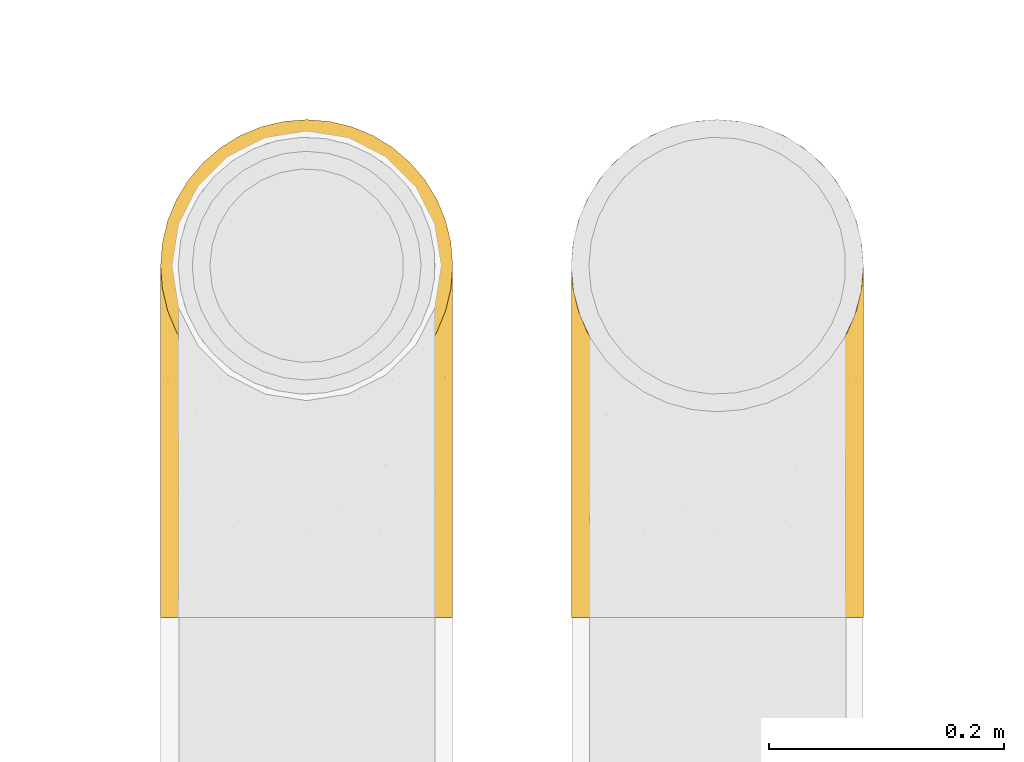
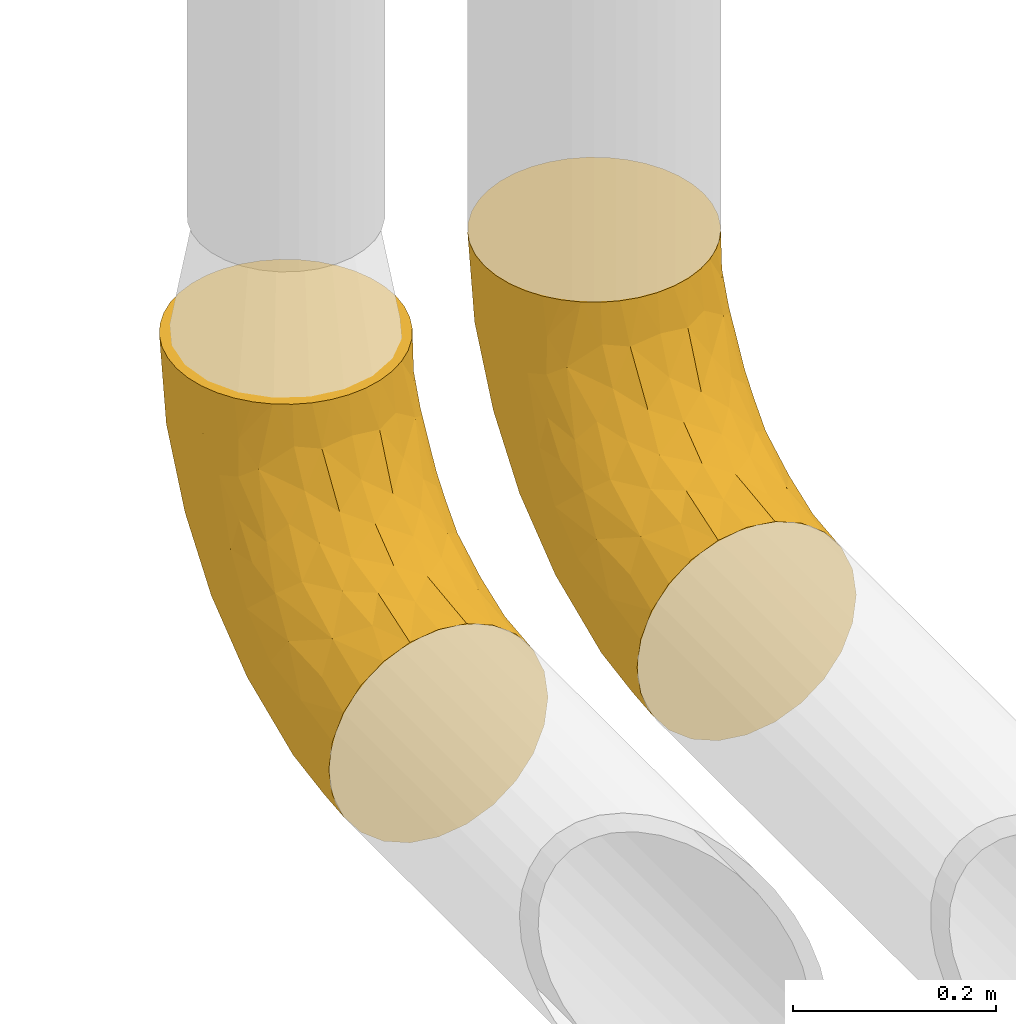
# One storey, part 41 of 93: 2 coverings.
"""IFC2X3 building model written with IfcOpenShell, lengths in millimetres."""

from ifc_helpers import new_model, entity, si_unit, converted_unit, derived_unit, direction, frame, origin, place, context, subcontext, project, spatial, faceted_brep, element, save


model = new_model("IFC2X3")

# Units and contexts
model_context = context("Model", 3, precision=0.01, world=origin(), true_north=direction((6.12303176911189e-17, 1.0)))
body_context = subcontext(model_context, "Body", "Model", "MODEL_VIEW")
ifc_project = project(units=[si_unit("LENGTHUNIT", "METRE", prefix="MILLI"), si_unit("AREAUNIT", "SQUARE_METRE"), si_unit("VOLUMEUNIT", "CUBIC_METRE"), converted_unit("PLANEANGLEUNIT", "DEGREE", entity("IfcRatioMeasure", 0.0174532925199433), si_unit("PLANEANGLEUNIT", "RADIAN"), dimensions=[0, 0, 0, 0, 0, 0, 0]), si_unit("MASSUNIT", "GRAM", prefix="KILO"), derived_unit("MASSDENSITYUNIT", [(si_unit("MASSUNIT", "GRAM", prefix="KILO"), 1), (si_unit("LENGTHUNIT", "METRE"), -3)]), derived_unit("MOMENTOFINERTIAUNIT", [(si_unit("LENGTHUNIT", "METRE"), 4)]), si_unit("TIMEUNIT", "SECOND"), si_unit("FREQUENCYUNIT", "HERTZ"), si_unit("THERMODYNAMICTEMPERATUREUNIT", "DEGREE_CELSIUS"), derived_unit("THERMALTRANSMITTANCEUNIT", [(si_unit("MASSUNIT", "GRAM", prefix="KILO"), 1), (si_unit("THERMODYNAMICTEMPERATUREUNIT", "KELVIN"), -1), (si_unit("TIMEUNIT", "SECOND"), -3)]), derived_unit("VOLUMETRICFLOWRATEUNIT", [(si_unit("LENGTHUNIT", "METRE"), 3), (si_unit("TIMEUNIT", "SECOND"), -1)]), derived_unit("MASSFLOWRATEUNIT", [(si_unit("MASSUNIT", "GRAM", prefix="KILO"), 1), (si_unit("TIMEUNIT", "SECOND"), -1)]), derived_unit("ROTATIONALFREQUENCYUNIT", [(si_unit("TIMEUNIT", "SECOND"), -1)]), si_unit("ELECTRICCURRENTUNIT", "AMPERE"), si_unit("ELECTRICVOLTAGEUNIT", "VOLT"), si_unit("POWERUNIT", "WATT"), si_unit("FORCEUNIT", "NEWTON", prefix="KILO"), si_unit("ILLUMINANCEUNIT", "LUX"), si_unit("LUMINOUSFLUXUNIT", "LUMEN"), si_unit("LUMINOUSINTENSITYUNIT", "CANDELA"), derived_unit("USERDEFINED", [(si_unit("MASSUNIT", "GRAM", prefix="KILO"), -1), (si_unit("LENGTHUNIT", "METRE"), -2), (si_unit("TIMEUNIT", "SECOND"), 3), (si_unit("LUMINOUSFLUXUNIT", "LUMEN"), 1)]), derived_unit("LINEARVELOCITYUNIT", [(si_unit("LENGTHUNIT", "METRE"), 1), (si_unit("TIMEUNIT", "SECOND"), -1)]), si_unit("PRESSUREUNIT", "PASCAL"), derived_unit("USERDEFINED", [(si_unit("LENGTHUNIT", "METRE"), -2), (si_unit("MASSUNIT", "GRAM", prefix="KILO"), 1), (si_unit("TIMEUNIT", "SECOND"), -2)]), derived_unit("LINEARFORCEUNIT", [(si_unit("MASSUNIT", "GRAM", prefix="KILO"), 1), (si_unit("LENGTHUNIT", "METRE"), 1), (si_unit("TIMEUNIT", "SECOND"), -2), (si_unit("LENGTHUNIT", "METRE"), -1)]), derived_unit("PLANARFORCEUNIT", [(si_unit("MASSUNIT", "GRAM", prefix="KILO"), 1), (si_unit("LENGTHUNIT", "METRE"), 1), (si_unit("TIMEUNIT", "SECOND"), -2), (si_unit("LENGTHUNIT", "METRE"), -2)])], contexts=[model_context])

# Site, building, storey
site_placement = place(None, origin())
site = spatial("IfcSite", under=ifc_project, at=site_placement, CompositionType="ELEMENT")
building_placement = place(site_placement, origin())
building = spatial("IfcBuilding", under=site, at=building_placement, CompositionType="ELEMENT")
storey_placement = place(building_placement, frame((0.0, 0.0, -4200.0)))
storey = spatial("IfcBuildingStorey", under=building, at=storey_placement, CompositionType="ELEMENT", Elevation=-4200.0)

# Coverings
covering_1_placement = place(storey_placement, frame((31303.9, 10648.4, 2673.9)))
element("IfcCovering", 1, at=covering_1_placement, inside=storey, Name=":ADSK_", ObjectType=":ADSK_", PredefinedType="INSULATION", context=body_context, shape_type="Brep", body=[
    faceted_brep([(249.06, 282.13, 426.1), (250.6, 301.6, 426.1), (249.06, 321.07, 426.1), (244.5, 340.07, 426.1), (237.02, 358.12, 426.1), (226.82, 374.78, 426.1), (214.13, 389.63, 426.1), (199.27, 402.32, 426.1), (182.61, 412.53, 426.1), (164.56, 420.0, 426.1), (145.56, 424.56, 426.1), (126.1, 426.1, 426.1), (106.62, 424.56, 426.1), (87.62, 420.0, 426.1), (69.57, 412.52, 426.1), (52.91, 402.32, 426.1), (38.06, 389.63, 426.1), (25.37, 374.77, 426.1), (15.16, 358.11, 426.1), (7.69, 340.06, 426.1), (3.13, 321.06, 426.1), (1.6, 301.6, 426.1), (3.13, 282.12, 426.1), (7.69, 263.12, 426.1), (15.17, 245.07, 426.1), (25.37, 228.41, 426.1), (38.06, 213.56, 426.1), (52.92, 200.87, 426.1), (69.58, 190.66, 426.1), (87.63, 183.19, 426.1), (106.63, 178.63, 426.1), (126.1, 177.1, 426.1), (145.57, 178.63, 426.1), (164.57, 183.19, 426.1), (182.62, 190.67, 426.1), (199.28, 200.87, 426.1), (214.13, 213.56, 426.1), (226.82, 228.42, 426.1), (237.03, 245.08, 426.1), (244.5, 263.13, 426.1), (38.06, 1.6, 214.13), (18.28, 1.6, 188.35), (5.84, 1.6, 158.32), (1.6, 1.6, 126.1), (5.84, 1.6, 93.87), (18.28, 1.6, 63.85), (38.06, 1.6, 38.06), (63.85, 1.6, 18.28), (93.87, 1.6, 5.84), (126.1, 1.6, 1.6), (158.32, 1.6, 5.84), (188.35, 1.6, 18.28), (214.13, 1.6, 38.06), (233.92, 1.6, 63.85), (246.35, 1.6, 93.87), (250.6, 1.6, 126.1), (246.35, 1.6, 158.32), (233.92, 1.6, 188.35), (214.13, 1.6, 214.13), (188.35, 1.6, 233.92), (158.32, 1.6, 246.35), (126.1, 1.6, 250.6), (93.87, 1.6, 246.35), (63.85, 1.6, 233.92), (126.1, 68.0, 6.82), (159.79, 159.76, 37.17), (171.65, 77.64, 17.24), (148.37, 97.22, 14.57), (170.98, 405.8, 327.19), (151.53, 392.04, 266.32), (148.43, 414.51, 336.7), (126.1, 132.77, 22.37), (126.1, 194.31, 47.86), (126.1, 405.32, 294.92), (126.1, 379.83, 233.38), (163.78, 320.36, 154.69), (158.07, 248.34, 85.81), (126.1, 301.76, 125.93), (216.14, 366.71, 300.91), (230.6, 325.62, 252.35), (215.18, 335.07, 229.77), (237.51, 94.41, 82.86), (220.0, 134.75, 68.32), (240.62, 179.18, 125.85), (126.1, 251.11, 82.67), (186.25, 211.76, 75.22), (126.1, 345.02, 176.58), (238.35, 342.12, 329.96), (222.84, 59.52, 52.19), (247.51, 211.65, 174.79), (242.96, 297.5, 252.75), (248.72, 276.6, 259.55), (247.51, 110.66, 117.26), (198.61, 95.34, 36.0), (238.33, 253.95, 178.0), (250.6, 116.4, 148.93), (250.6, 168.27, 176.65), (185.0, 369.41, 245.67), (250.6, 213.73, 213.96), (196.36, 306.0, 162.34), (204.33, 391.55, 352.45), (126.1, 420.87, 359.69), (250.6, 295.83, 367.57), (248.1, 308.28, 319.13), (250.6, 251.04, 259.42), (250.6, 278.76, 311.29), (250.6, 60.12, 131.86), (210.72, 234.78, 111.84), (228.5, 221.69, 127.68), (202.78, 163.96, 62.63), (223.0, 288.95, 180.25), (161.59, 111.98, 283.07), (126.1, 89.35, 274.11), (154.22, 71.87, 261.78), (245.5, 64.74, 168.98), (229.55, 215.82, 340.36), (225.61, 222.14, 380.61), (214.98, 201.51, 353.11), (208.87, 126.52, 261.04), (222.51, 172.37, 285.47), (202.61, 163.8, 306.07), (240.31, 234.78, 334.75), (182.2, 167.67, 336.17), (158.82, 173.96, 374.65), (156.41, 143.34, 316.38), (247.49, 121.95, 181.78), (244.95, 258.85, 371.73), (229.45, 143.25, 244.15), (246.68, 169.65, 216.03), (229.97, 51.0, 200.06), (126.1, 47.02, 256.58), (175.48, 45.74, 245.7), (182.39, 93.2, 260.83), (126.1, 171.12, 380.67), (126.1, 153.58, 338.35), (183.62, 136.31, 292.7), (126.1, 125.69, 302.0), (244.1, 205.48, 264.25), (248.44, 249.33, 302.28), (209.02, 66.24, 229.31), (235.25, 204.54, 297.75), (235.58, 177.77, 262.06), (183.86, 185.41, 379.14), (235.31, 107.5, 210.47), (5.51, 169.66, 216.03), (22.75, 143.22, 244.14), (16.61, 177.76, 262.04), (90.61, 111.98, 283.07), (69.8, 93.2, 260.83), (97.97, 71.87, 261.78), (26.59, 222.13, 380.61), (1.6, 116.4, 148.93), (4.7, 121.95, 181.78), (1.6, 168.27, 176.65), (95.79, 143.34, 316.38), (22.64, 215.81, 340.36), (11.89, 234.77, 334.74), (68.58, 136.3, 292.7), (93.38, 173.96, 374.65), (6.69, 64.74, 168.98), (1.6, 60.12, 131.86), (1.6, 213.73, 213.96), (8.09, 205.49, 264.24), (16.94, 204.53, 297.74), (43.34, 126.53, 261.06), (22.22, 51.0, 200.06), (43.17, 66.24, 229.31), (70.0, 167.66, 336.17), (1.6, 278.76, 311.29), (7.24, 258.84, 371.72), (1.6, 295.83, 367.57), (76.71, 45.74, 245.7), (68.34, 185.4, 379.14), (16.88, 107.5, 210.47), (37.22, 201.5, 353.11), (29.69, 172.36, 285.46), (49.59, 163.8, 306.07), (3.75, 249.33, 302.29), (1.6, 251.04, 259.42), (4.68, 110.66, 117.26), (29.2, 288.95, 180.25), (21.6, 325.63, 252.36), (37.02, 335.08, 229.77), (4.68, 211.65, 174.79), (67.18, 369.41, 245.69), (81.2, 405.8, 327.2), (100.65, 392.04, 266.32), (13.83, 342.12, 329.97), (14.68, 94.41, 82.86), (29.35, 59.51, 52.19), (53.58, 95.34, 36.0), (9.24, 297.5, 252.75), (3.47, 276.6, 259.54), (11.57, 179.18, 125.85), (92.4, 159.76, 37.17), (80.54, 77.64, 17.24), (47.86, 391.55, 352.45), (32.19, 134.74, 68.32), (88.4, 320.36, 154.69), (55.83, 306.02, 162.36), (103.83, 97.22, 14.57), (94.12, 248.34, 85.81), (65.94, 211.76, 75.22), (41.48, 234.79, 111.84), (103.76, 414.51, 336.71), (4.09, 308.29, 319.13), (13.86, 253.95, 178.0), (23.69, 221.69, 127.67), (36.04, 366.7, 300.91), (49.41, 163.97, 62.64)], [[[0, 1, 2, 3, 4, 5, 6, 7, 8, 9, 10, 11, 12, 13, 14, 15, 16, 17, 18, 19, 20, 21, 22, 23, 24, 25, 26, 27, 28, 29, 30, 31, 32, 33, 34, 35, 36, 37, 38, 39]], [[40, 41, 42, 43, 44, 45, 46, 47, 48, 49, 50, 51, 52, 53, 54, 55, 56, 57, 58, 59, 60, 61, 62, 63]], [[49, 64, 50]], [[65, 66, 67]], [[68, 69, 70]], [[65, 71, 72]], [[71, 65, 67]], [[73, 69, 74]], [[75, 76, 77]], [[78, 79, 80]], [[65, 72, 76]], [[51, 50, 66]], [[81, 82, 83]], [[84, 76, 72]], [[76, 85, 65]], [[74, 69, 86]], [[5, 87, 78]], [[52, 88, 53]], [[89, 90, 91]], [[55, 54, 92]], [[82, 88, 93]], [[94, 89, 83]], [[87, 90, 79]], [[95, 89, 96]], [[5, 4, 87]], [[83, 89, 92]], [[90, 89, 94]], [[78, 80, 97]], [[65, 85, 93]], [[95, 92, 89]], [[96, 89, 98]], [[99, 75, 97]], [[3, 87, 4]], [[90, 94, 79]], [[8, 68, 9]], [[75, 77, 86]], [[100, 7, 6]], [[83, 92, 81]], [[70, 10, 9]], [[101, 70, 73]], [[54, 81, 92]], [[68, 70, 9]], [[97, 100, 78]], [[7, 100, 8]], [[8, 100, 68]], [[101, 11, 10]], [[2, 102, 103]], [[100, 6, 5]], [[104, 91, 105]], [[102, 105, 103]], [[92, 95, 106]], [[1, 102, 2]], [[81, 54, 53]], [[107, 108, 82]], [[68, 97, 69]], [[2, 103, 3]], [[98, 89, 91]], [[90, 103, 91]], [[90, 87, 103]], [[107, 85, 99]], [[103, 87, 3]], [[100, 97, 68]], [[100, 5, 78]], [[93, 52, 51]], [[75, 69, 97]], [[75, 86, 69]], [[88, 81, 53]], [[55, 92, 106]], [[93, 51, 66]], [[109, 82, 93]], [[108, 94, 83]], [[79, 94, 110]], [[107, 99, 110]], [[85, 75, 99]], [[77, 76, 84]], [[75, 85, 76]], [[110, 94, 108]], [[109, 107, 82]], [[82, 108, 83]], [[110, 108, 107]], [[67, 50, 64]], [[93, 66, 65]], [[80, 79, 110]], [[78, 87, 79]], [[110, 99, 80]], [[97, 80, 99]], [[73, 70, 69]], [[10, 70, 101]], [[50, 67, 66]], [[71, 67, 64]], [[105, 91, 103]], [[91, 104, 98]], [[93, 88, 52]], [[81, 88, 82]], [[93, 85, 109]], [[107, 109, 85]], [[111, 112, 113]], [[56, 55, 106]], [[106, 114, 56]], [[115, 116, 117]], [[118, 119, 120]], [[116, 115, 121]], [[95, 114, 106]], [[122, 123, 124]], [[95, 125, 114]], [[102, 39, 126]], [[119, 118, 127]], [[96, 98, 128]], [[114, 57, 56]], [[57, 129, 58]], [[36, 35, 116]], [[61, 60, 130]], [[113, 131, 132]], [[32, 133, 123]], [[134, 123, 133]], [[113, 112, 130]], [[126, 116, 121]], [[131, 113, 60]], [[124, 111, 135]], [[122, 124, 135]], [[111, 136, 112]], [[128, 98, 137]], [[137, 104, 138]], [[132, 135, 111]], [[126, 105, 102]], [[60, 113, 130]], [[127, 118, 139]], [[126, 39, 38]], [[140, 121, 115]], [[1, 0, 102]], [[126, 121, 138]], [[38, 37, 116]], [[129, 139, 58]], [[0, 39, 102]], [[127, 141, 119]], [[116, 126, 38]], [[142, 34, 33]], [[142, 123, 122]], [[137, 98, 104]], [[31, 133, 32]], [[139, 132, 131]], [[123, 134, 124]], [[35, 34, 142]], [[35, 117, 116]], [[124, 134, 136]], [[117, 122, 120]], [[33, 32, 123]], [[33, 123, 142]], [[37, 36, 116]], [[58, 139, 59]], [[129, 114, 143]], [[105, 138, 104]], [[125, 128, 143]], [[125, 95, 96]], [[118, 135, 132]], [[120, 122, 135]], [[132, 139, 118]], [[127, 139, 143]], [[114, 129, 57]], [[139, 129, 143]], [[60, 59, 131]], [[139, 131, 59]], [[128, 125, 96]], [[143, 114, 125]], [[118, 120, 135]], [[117, 120, 119]], [[143, 128, 127]], [[141, 128, 137]], [[136, 111, 124]], [[132, 111, 113]], [[122, 117, 142]], [[35, 142, 117]], [[117, 119, 115]], [[119, 141, 140]], [[126, 138, 105]], [[137, 138, 121]], [[128, 141, 127]], [[140, 141, 137]], [[121, 140, 137]], [[119, 140, 115]], [[144, 145, 146]], [[147, 148, 149]], [[62, 61, 130]], [[149, 62, 130]], [[26, 150, 27]], [[151, 152, 153]], [[134, 154, 136]], [[155, 150, 156]], [[130, 112, 149]], [[157, 147, 154]], [[152, 144, 153]], [[154, 134, 158]], [[42, 159, 160]], [[161, 153, 144]], [[162, 146, 163]], [[160, 43, 42]], [[41, 159, 42]], [[164, 148, 157]], [[41, 40, 165]], [[40, 63, 166]], [[158, 167, 154]], [[151, 160, 159]], [[168, 169, 170]], [[63, 171, 166]], [[23, 170, 169]], [[152, 151, 159]], [[29, 172, 158]], [[173, 166, 145]], [[133, 31, 30]], [[149, 148, 171]], [[144, 162, 161]], [[172, 29, 28]], [[174, 172, 27]], [[149, 171, 62]], [[174, 27, 150]], [[158, 134, 133]], [[155, 174, 150]], [[167, 158, 172]], [[174, 175, 176]], [[162, 156, 177]], [[169, 168, 177]], [[162, 178, 161]], [[26, 25, 150]], [[166, 164, 145]], [[23, 169, 24]], [[169, 150, 24]], [[169, 156, 150]], [[136, 154, 147]], [[22, 21, 170]], [[133, 30, 158]], [[150, 25, 24]], [[23, 22, 170]], [[157, 154, 167]], [[178, 177, 168]], [[112, 136, 147]], [[29, 158, 30]], [[165, 159, 41]], [[165, 166, 173]], [[167, 176, 157]], [[157, 176, 164]], [[164, 175, 145]], [[166, 148, 164]], [[166, 165, 40]], [[159, 165, 173]], [[166, 171, 148]], [[63, 62, 171]], [[159, 173, 152]], [[144, 152, 173]], [[174, 176, 167]], [[164, 176, 175]], [[146, 145, 175]], [[144, 173, 145]], [[148, 147, 157]], [[147, 149, 112]], [[27, 172, 28]], [[174, 167, 172]], [[163, 156, 162]], [[175, 174, 155]], [[162, 177, 178]], [[169, 177, 156]], [[163, 175, 155]], [[144, 146, 162]], [[175, 163, 146]], [[156, 163, 155]], [[160, 179, 43]], [[180, 181, 182]], [[151, 153, 183]], [[184, 185, 186]], [[183, 179, 151]], [[186, 74, 86]], [[153, 161, 183]], [[187, 19, 18]], [[188, 44, 179]], [[46, 189, 190]], [[181, 191, 187]], [[183, 161, 192]], [[186, 73, 74]], [[193, 179, 183]], [[194, 195, 190]], [[184, 196, 185]], [[64, 49, 48]], [[44, 188, 45]], [[193, 188, 179]], [[189, 188, 197]], [[14, 13, 185]], [[198, 199, 184]], [[195, 200, 48]], [[201, 194, 202]], [[182, 184, 199]], [[201, 77, 84]], [[199, 203, 180]], [[194, 201, 72]], [[45, 189, 46]], [[13, 12, 204]], [[205, 192, 168]], [[14, 196, 15]], [[170, 21, 20]], [[186, 86, 198]], [[187, 205, 19]], [[19, 205, 20]], [[20, 205, 170]], [[151, 179, 160]], [[205, 191, 192]], [[193, 206, 207]], [[208, 17, 196]], [[193, 197, 188]], [[43, 179, 44]], [[187, 17, 208]], [[46, 190, 47]], [[84, 72, 201]], [[198, 184, 186]], [[86, 77, 198]], [[194, 72, 71]], [[186, 204, 73]], [[204, 186, 185]], [[15, 196, 16]], [[184, 208, 196]], [[192, 161, 178]], [[12, 11, 101]], [[17, 187, 18]], [[47, 195, 48]], [[12, 101, 204]], [[181, 180, 206]], [[17, 16, 196]], [[14, 185, 196]], [[168, 170, 205]], [[206, 183, 191]], [[183, 206, 193]], [[187, 191, 205]], [[200, 71, 64]], [[197, 209, 190]], [[194, 190, 202]], [[181, 206, 191]], [[207, 180, 203]], [[198, 202, 199]], [[203, 199, 202]], [[202, 198, 201]], [[77, 201, 198]], [[209, 203, 202]], [[207, 197, 193]], [[180, 207, 206]], [[197, 207, 203]], [[190, 195, 47]], [[200, 195, 194]], [[187, 208, 181]], [[182, 181, 208]], [[184, 182, 208]], [[199, 180, 182]], [[204, 185, 13]], [[73, 204, 101]], [[71, 200, 194]], [[48, 200, 64]], [[183, 192, 191]], [[168, 192, 178]], [[188, 189, 45]], [[190, 189, 197]], [[203, 209, 197]], [[202, 190, 209]]]),
])
covering_2_placement = place(storey_placement, frame((30953.9, 10648.4, 2673.9)))
element("IfcCovering", 2, at=covering_2_placement, inside=storey, Name=":ADSK_", ObjectType=":ADSK_", PredefinedType="INSULATION", context=body_context, shape_type="Brep", body=[
    faceted_brep([(249.06, 282.13, 426.1), (250.6, 301.6, 426.1), (249.06, 321.07, 426.1), (244.5, 340.07, 426.1), (237.02, 358.12, 426.1), (226.82, 374.78, 426.1), (214.13, 389.63, 426.1), (199.27, 402.32, 426.1), (182.61, 412.53, 426.1), (164.56, 420.0, 426.1), (145.56, 424.56, 426.1), (126.1, 426.1, 426.1), (106.62, 424.56, 426.1), (87.62, 420.0, 426.1), (69.57, 412.52, 426.1), (52.91, 402.32, 426.1), (38.06, 389.63, 426.1), (25.37, 374.77, 426.1), (15.16, 358.11, 426.1), (7.69, 340.06, 426.1), (3.13, 321.06, 426.1), (1.6, 301.6, 426.1), (3.13, 282.12, 426.1), (7.69, 263.12, 426.1), (15.17, 245.07, 426.1), (25.37, 228.41, 426.1), (38.06, 213.56, 426.1), (52.92, 200.87, 426.1), (69.58, 190.66, 426.1), (87.63, 183.19, 426.1), (106.63, 178.63, 426.1), (126.1, 177.1, 426.1), (145.57, 178.63, 426.1), (164.57, 183.19, 426.1), (182.62, 190.67, 426.1), (199.28, 200.87, 426.1), (214.13, 213.56, 426.1), (226.82, 228.42, 426.1), (237.03, 245.08, 426.1), (244.5, 263.13, 426.1), (38.06, 1.6, 214.13), (18.28, 1.6, 188.35), (5.84, 1.6, 158.32), (1.6, 1.6, 126.1), (5.84, 1.6, 93.87), (18.28, 1.6, 63.85), (38.06, 1.6, 38.06), (63.85, 1.6, 18.28), (93.87, 1.6, 5.84), (126.1, 1.6, 1.6), (158.32, 1.6, 5.84), (188.35, 1.6, 18.28), (214.13, 1.6, 38.06), (233.92, 1.6, 63.85), (246.35, 1.6, 93.87), (250.6, 1.6, 126.1), (246.35, 1.6, 158.32), (233.92, 1.6, 188.35), (214.13, 1.6, 214.13), (188.35, 1.6, 233.92), (158.32, 1.6, 246.35), (126.1, 1.6, 250.6), (93.87, 1.6, 246.35), (63.85, 1.6, 233.92), (126.1, 68.0, 6.82), (159.79, 159.76, 37.17), (171.65, 77.64, 17.24), (148.37, 97.22, 14.57), (170.98, 405.8, 327.19), (151.53, 392.04, 266.32), (148.43, 414.51, 336.7), (126.1, 132.77, 22.37), (126.1, 194.31, 47.86), (126.1, 405.32, 294.92), (126.1, 379.83, 233.38), (163.78, 320.36, 154.69), (158.07, 248.34, 85.81), (126.1, 301.76, 125.93), (216.14, 366.71, 300.91), (230.6, 325.62, 252.35), (215.18, 335.07, 229.77), (237.51, 94.41, 82.86), (220.0, 134.75, 68.32), (240.62, 179.18, 125.85), (126.1, 251.11, 82.67), (186.25, 211.76, 75.22), (126.1, 345.02, 176.58), (238.35, 342.12, 329.96), (222.84, 59.52, 52.19), (247.51, 211.65, 174.79), (242.96, 297.5, 252.75), (248.72, 276.6, 259.55), (247.51, 110.66, 117.26), (198.61, 95.34, 36.0), (238.33, 253.95, 178.0), (250.6, 116.4, 148.93), (250.6, 168.27, 176.65), (185.0, 369.41, 245.67), (250.6, 213.73, 213.96), (196.36, 306.0, 162.34), (204.33, 391.55, 352.45), (126.1, 420.87, 359.69), (250.6, 295.83, 367.57), (248.1, 308.28, 319.13), (250.6, 251.04, 259.42), (250.6, 278.76, 311.29), (250.6, 60.12, 131.86), (210.72, 234.78, 111.84), (228.5, 221.69, 127.68), (202.78, 163.96, 62.63), (223.0, 288.95, 180.25), (161.59, 111.98, 283.07), (126.1, 89.35, 274.11), (154.22, 71.87, 261.78), (245.5, 64.74, 168.98), (229.55, 215.82, 340.36), (225.61, 222.14, 380.61), (214.98, 201.51, 353.11), (208.87, 126.52, 261.04), (222.51, 172.37, 285.47), (202.61, 163.8, 306.07), (240.31, 234.78, 334.75), (182.2, 167.67, 336.17), (158.82, 173.96, 374.65), (156.41, 143.34, 316.38), (247.49, 121.95, 181.78), (244.95, 258.85, 371.73), (229.45, 143.25, 244.15), (246.68, 169.65, 216.03), (229.97, 51.0, 200.06), (126.1, 47.02, 256.58), (175.48, 45.74, 245.7), (182.39, 93.2, 260.83), (126.1, 171.12, 380.67), (126.1, 153.58, 338.35), (183.62, 136.31, 292.7), (126.1, 125.69, 302.0), (244.1, 205.48, 264.25), (248.44, 249.33, 302.28), (209.02, 66.24, 229.31), (235.25, 204.54, 297.75), (235.58, 177.77, 262.06), (183.86, 185.41, 379.14), (235.31, 107.5, 210.47), (5.51, 169.66, 216.03), (22.75, 143.22, 244.14), (16.61, 177.76, 262.04), (90.61, 111.98, 283.07), (69.8, 93.2, 260.83), (97.97, 71.87, 261.78), (26.59, 222.13, 380.61), (1.6, 116.4, 148.93), (4.7, 121.95, 181.78), (1.6, 168.27, 176.65), (95.79, 143.34, 316.38), (22.64, 215.81, 340.36), (11.89, 234.77, 334.74), (68.58, 136.3, 292.7), (93.38, 173.96, 374.65), (6.69, 64.74, 168.98), (1.6, 60.12, 131.86), (1.6, 213.73, 213.96), (8.09, 205.49, 264.24), (16.94, 204.53, 297.74), (43.34, 126.53, 261.06), (22.22, 51.0, 200.06), (43.17, 66.24, 229.31), (70.0, 167.66, 336.17), (1.6, 278.76, 311.29), (7.24, 258.84, 371.72), (1.6, 295.83, 367.57), (76.71, 45.74, 245.7), (68.34, 185.4, 379.14), (16.88, 107.5, 210.47), (37.22, 201.5, 353.11), (29.69, 172.36, 285.46), (49.59, 163.8, 306.07), (3.75, 249.33, 302.29), (1.6, 251.04, 259.42), (4.68, 110.66, 117.26), (29.2, 288.95, 180.25), (21.6, 325.63, 252.36), (37.02, 335.08, 229.77), (4.68, 211.65, 174.79), (67.18, 369.41, 245.69), (81.2, 405.8, 327.2), (100.65, 392.04, 266.32), (13.83, 342.12, 329.97), (14.68, 94.41, 82.86), (29.35, 59.51, 52.19), (53.58, 95.34, 36.0), (9.24, 297.5, 252.75), (3.47, 276.6, 259.54), (11.57, 179.18, 125.85), (92.4, 159.76, 37.17), (80.54, 77.64, 17.24), (47.86, 391.55, 352.45), (32.19, 134.74, 68.32), (88.4, 320.36, 154.69), (55.83, 306.02, 162.36), (103.83, 97.22, 14.57), (94.12, 248.34, 85.81), (65.94, 211.76, 75.22), (41.48, 234.79, 111.84), (103.76, 414.51, 336.71), (4.09, 308.29, 319.13), (13.86, 253.95, 178.0), (23.69, 221.69, 127.67), (36.04, 366.7, 300.91), (49.41, 163.97, 62.64)], [[[0, 1, 2, 3, 4, 5, 6, 7, 8, 9, 10, 11, 12, 13, 14, 15, 16, 17, 18, 19, 20, 21, 22, 23, 24, 25, 26, 27, 28, 29, 30, 31, 32, 33, 34, 35, 36, 37, 38, 39]], [[40, 41, 42, 43, 44, 45, 46, 47, 48, 49, 50, 51, 52, 53, 54, 55, 56, 57, 58, 59, 60, 61, 62, 63]], [[49, 64, 50]], [[65, 66, 67]], [[68, 69, 70]], [[65, 71, 72]], [[71, 65, 67]], [[73, 69, 74]], [[75, 76, 77]], [[78, 79, 80]], [[65, 72, 76]], [[51, 50, 66]], [[81, 82, 83]], [[84, 76, 72]], [[76, 85, 65]], [[74, 69, 86]], [[5, 87, 78]], [[52, 88, 53]], [[89, 90, 91]], [[55, 54, 92]], [[82, 88, 93]], [[94, 89, 83]], [[87, 90, 79]], [[95, 89, 96]], [[5, 4, 87]], [[83, 89, 92]], [[90, 89, 94]], [[78, 80, 97]], [[65, 85, 93]], [[95, 92, 89]], [[96, 89, 98]], [[99, 75, 97]], [[3, 87, 4]], [[90, 94, 79]], [[8, 68, 9]], [[75, 77, 86]], [[100, 7, 6]], [[83, 92, 81]], [[70, 10, 9]], [[101, 70, 73]], [[54, 81, 92]], [[68, 70, 9]], [[97, 100, 78]], [[7, 100, 8]], [[8, 100, 68]], [[101, 11, 10]], [[2, 102, 103]], [[100, 6, 5]], [[104, 91, 105]], [[102, 105, 103]], [[92, 95, 106]], [[1, 102, 2]], [[81, 54, 53]], [[107, 108, 82]], [[68, 97, 69]], [[2, 103, 3]], [[98, 89, 91]], [[90, 103, 91]], [[90, 87, 103]], [[107, 85, 99]], [[103, 87, 3]], [[100, 97, 68]], [[100, 5, 78]], [[93, 52, 51]], [[75, 69, 97]], [[75, 86, 69]], [[88, 81, 53]], [[55, 92, 106]], [[93, 51, 66]], [[109, 82, 93]], [[108, 94, 83]], [[79, 94, 110]], [[107, 99, 110]], [[85, 75, 99]], [[77, 76, 84]], [[75, 85, 76]], [[110, 94, 108]], [[109, 107, 82]], [[82, 108, 83]], [[110, 108, 107]], [[67, 50, 64]], [[93, 66, 65]], [[80, 79, 110]], [[78, 87, 79]], [[110, 99, 80]], [[97, 80, 99]], [[73, 70, 69]], [[10, 70, 101]], [[50, 67, 66]], [[71, 67, 64]], [[105, 91, 103]], [[91, 104, 98]], [[93, 88, 52]], [[81, 88, 82]], [[93, 85, 109]], [[107, 109, 85]], [[111, 112, 113]], [[56, 55, 106]], [[106, 114, 56]], [[115, 116, 117]], [[118, 119, 120]], [[116, 115, 121]], [[95, 114, 106]], [[122, 123, 124]], [[95, 125, 114]], [[102, 39, 126]], [[119, 118, 127]], [[96, 98, 128]], [[114, 57, 56]], [[57, 129, 58]], [[36, 35, 116]], [[61, 60, 130]], [[113, 131, 132]], [[32, 133, 123]], [[134, 123, 133]], [[113, 112, 130]], [[126, 116, 121]], [[131, 113, 60]], [[124, 111, 135]], [[122, 124, 135]], [[111, 136, 112]], [[128, 98, 137]], [[137, 104, 138]], [[132, 135, 111]], [[126, 105, 102]], [[60, 113, 130]], [[127, 118, 139]], [[126, 39, 38]], [[140, 121, 115]], [[1, 0, 102]], [[126, 121, 138]], [[38, 37, 116]], [[129, 139, 58]], [[0, 39, 102]], [[127, 141, 119]], [[116, 126, 38]], [[142, 34, 33]], [[142, 123, 122]], [[137, 98, 104]], [[31, 133, 32]], [[139, 132, 131]], [[123, 134, 124]], [[35, 34, 142]], [[35, 117, 116]], [[124, 134, 136]], [[117, 122, 120]], [[33, 32, 123]], [[33, 123, 142]], [[37, 36, 116]], [[58, 139, 59]], [[129, 114, 143]], [[105, 138, 104]], [[125, 128, 143]], [[125, 95, 96]], [[118, 135, 132]], [[120, 122, 135]], [[132, 139, 118]], [[127, 139, 143]], [[114, 129, 57]], [[139, 129, 143]], [[60, 59, 131]], [[139, 131, 59]], [[128, 125, 96]], [[143, 114, 125]], [[118, 120, 135]], [[117, 120, 119]], [[143, 128, 127]], [[141, 128, 137]], [[136, 111, 124]], [[132, 111, 113]], [[122, 117, 142]], [[35, 142, 117]], [[117, 119, 115]], [[119, 141, 140]], [[126, 138, 105]], [[137, 138, 121]], [[128, 141, 127]], [[140, 141, 137]], [[121, 140, 137]], [[119, 140, 115]], [[144, 145, 146]], [[147, 148, 149]], [[62, 61, 130]], [[149, 62, 130]], [[26, 150, 27]], [[151, 152, 153]], [[134, 154, 136]], [[155, 150, 156]], [[130, 112, 149]], [[157, 147, 154]], [[152, 144, 153]], [[154, 134, 158]], [[42, 159, 160]], [[161, 153, 144]], [[162, 146, 163]], [[160, 43, 42]], [[41, 159, 42]], [[164, 148, 157]], [[41, 40, 165]], [[40, 63, 166]], [[158, 167, 154]], [[151, 160, 159]], [[168, 169, 170]], [[63, 171, 166]], [[23, 170, 169]], [[152, 151, 159]], [[29, 172, 158]], [[173, 166, 145]], [[133, 31, 30]], [[149, 148, 171]], [[144, 162, 161]], [[172, 29, 28]], [[174, 172, 27]], [[149, 171, 62]], [[174, 27, 150]], [[158, 134, 133]], [[155, 174, 150]], [[167, 158, 172]], [[174, 175, 176]], [[162, 156, 177]], [[169, 168, 177]], [[162, 178, 161]], [[26, 25, 150]], [[166, 164, 145]], [[23, 169, 24]], [[169, 150, 24]], [[169, 156, 150]], [[136, 154, 147]], [[22, 21, 170]], [[133, 30, 158]], [[150, 25, 24]], [[23, 22, 170]], [[157, 154, 167]], [[178, 177, 168]], [[112, 136, 147]], [[29, 158, 30]], [[165, 159, 41]], [[165, 166, 173]], [[167, 176, 157]], [[157, 176, 164]], [[164, 175, 145]], [[166, 148, 164]], [[166, 165, 40]], [[159, 165, 173]], [[166, 171, 148]], [[63, 62, 171]], [[159, 173, 152]], [[144, 152, 173]], [[174, 176, 167]], [[164, 176, 175]], [[146, 145, 175]], [[144, 173, 145]], [[148, 147, 157]], [[147, 149, 112]], [[27, 172, 28]], [[174, 167, 172]], [[163, 156, 162]], [[175, 174, 155]], [[162, 177, 178]], [[169, 177, 156]], [[163, 175, 155]], [[144, 146, 162]], [[175, 163, 146]], [[156, 163, 155]], [[160, 179, 43]], [[180, 181, 182]], [[151, 153, 183]], [[184, 185, 186]], [[183, 179, 151]], [[186, 74, 86]], [[153, 161, 183]], [[187, 19, 18]], [[188, 44, 179]], [[46, 189, 190]], [[181, 191, 187]], [[183, 161, 192]], [[186, 73, 74]], [[193, 179, 183]], [[194, 195, 190]], [[184, 196, 185]], [[64, 49, 48]], [[44, 188, 45]], [[193, 188, 179]], [[189, 188, 197]], [[14, 13, 185]], [[198, 199, 184]], [[195, 200, 48]], [[201, 194, 202]], [[182, 184, 199]], [[201, 77, 84]], [[199, 203, 180]], [[194, 201, 72]], [[45, 189, 46]], [[13, 12, 204]], [[205, 192, 168]], [[14, 196, 15]], [[170, 21, 20]], [[186, 86, 198]], [[187, 205, 19]], [[19, 205, 20]], [[20, 205, 170]], [[151, 179, 160]], [[205, 191, 192]], [[193, 206, 207]], [[208, 17, 196]], [[193, 197, 188]], [[43, 179, 44]], [[187, 17, 208]], [[46, 190, 47]], [[84, 72, 201]], [[198, 184, 186]], [[86, 77, 198]], [[194, 72, 71]], [[186, 204, 73]], [[204, 186, 185]], [[15, 196, 16]], [[184, 208, 196]], [[192, 161, 178]], [[12, 11, 101]], [[17, 187, 18]], [[47, 195, 48]], [[12, 101, 204]], [[181, 180, 206]], [[17, 16, 196]], [[14, 185, 196]], [[168, 170, 205]], [[206, 183, 191]], [[183, 206, 193]], [[187, 191, 205]], [[200, 71, 64]], [[197, 209, 190]], [[194, 190, 202]], [[181, 206, 191]], [[207, 180, 203]], [[198, 202, 199]], [[203, 199, 202]], [[202, 198, 201]], [[77, 201, 198]], [[209, 203, 202]], [[207, 197, 193]], [[180, 207, 206]], [[197, 207, 203]], [[190, 195, 47]], [[200, 195, 194]], [[187, 208, 181]], [[182, 181, 208]], [[184, 182, 208]], [[199, 180, 182]], [[204, 185, 13]], [[73, 204, 101]], [[71, 200, 194]], [[48, 200, 64]], [[183, 192, 191]], [[168, 192, 178]], [[188, 189, 45]], [[190, 189, 197]], [[203, 209, 197]], [[202, 190, 209]]]),
])

save(model, "model.ifc")
